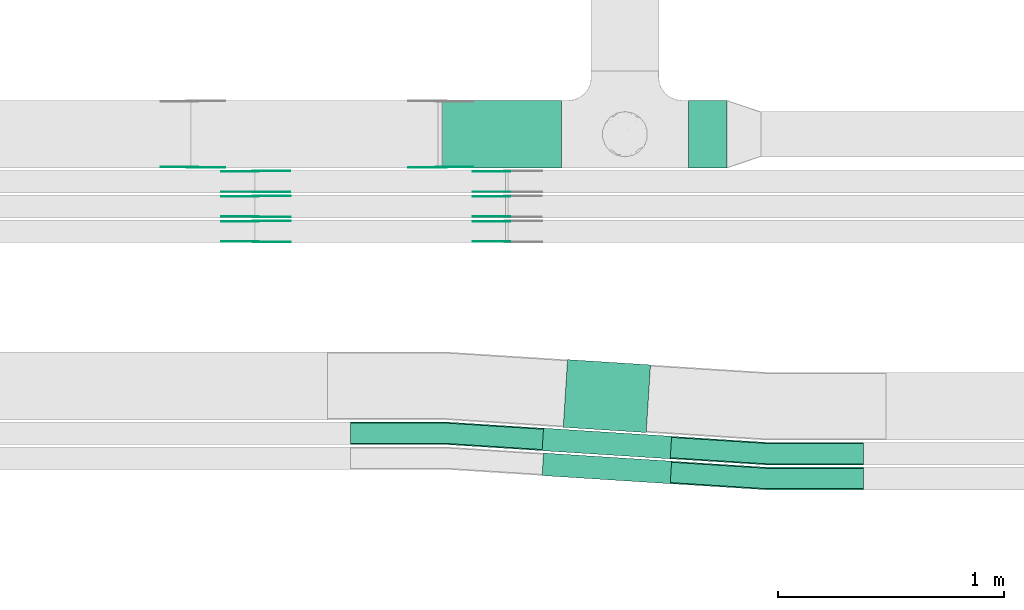
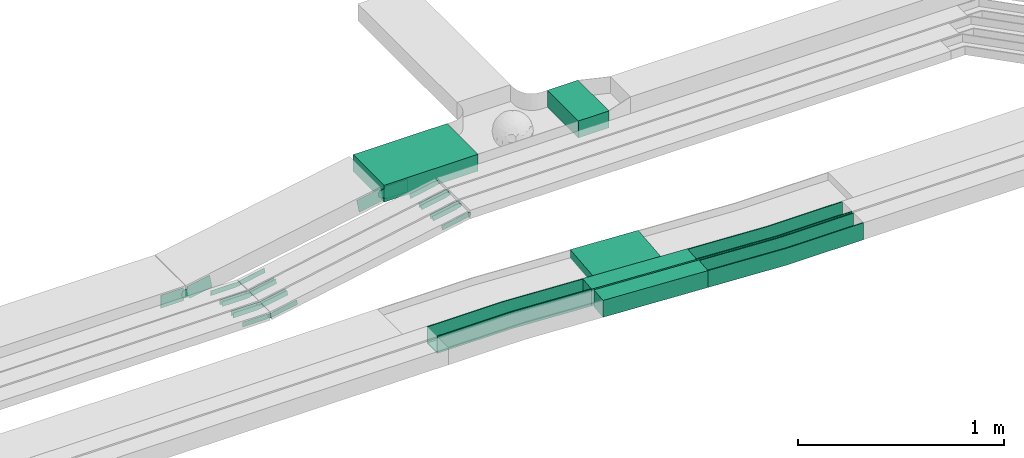
# One storey, part 11 of 32: 25 flow fittings, 5 flow segments.
"""IFC2X3 building model written with IfcOpenShell, lengths in millimetres."""

import ifcopenshell
import ifcopenshell.guid

model = None  # the IFC model being written
_history = None  # IfcOwnerHistory: only IFC2X3 demands one
_inside = {}  # id of a spatial element -> (the spatial element, [elements in it])
_under = {}  # id of a project, library or spatial element -> (it, [spatial elements below it])
_declared = {}  # id of a project -> (the project, [libraries it declares])
_typed = {}  # id of a type object -> (the type object, [elements of that type])
_made_of = {}  # id of a material, layer set ... -> (it, [elements and type objects made of it])


def new_model(schema):
    """Start an empty IFC model of exactly this schema.

    Asked for "IFC4X3", IfcOpenShell would pick the latest addendum, in which some entities
    have other attributes; the version numbers below select the first issue.
    IFC2X3 requires an IfcOwnerHistory on every rooted entity: one is made here for all.
    """
    global model, _history
    if schema == "IFC4X3":
        model = ifcopenshell.file(schema_version=(4, 3, 0, 0))
    else:
        model = ifcopenshell.file(schema=schema)
    _inside.clear()
    _under.clear()
    _declared.clear()
    _typed.clear()
    _made_of.clear()
    _history = None
    if model.schema == "IFC2X3":
        org = make("IfcOrganization", Name="unknown")
        user = make(
            "IfcPersonAndOrganization",
            ThePerson=make("IfcPerson", FamilyName="unknown"),
            TheOrganization=org,
        )
        app = make(
            "IfcApplication",
            ApplicationDeveloper=org,
            Version="unknown",
            ApplicationFullName="unknown",
            ApplicationIdentifier="unknown",
        )
        _history = make(
            "IfcOwnerHistory",
            OwningUser=user,
            OwningApplication=app,
            ChangeAction="ADDED",
            CreationDate=0,
        )
    return model


def make(cls, **values):
    """One entity of the class cls with the attributes given. An attribute that is None is left unset."""
    return model.create_entity(
        cls, **{name: value for name, value in values.items() if value is not None}
    )


def entity(cls, *values):
    """Any entity or typed value of the class cls, its attributes in the order of the schema. None: left unset."""
    e = model.create_entity(cls)
    for i, value in enumerate(values):
        if value is not None:
            e[i] = value
    return e


def rooted(cls, **values):
    """An entity with a GlobalId (a new one), such as an element, a storey or a relation."""
    return make(cls, GlobalId=ifcopenshell.guid.new(), OwnerHistory=_history, **values)


def si_unit(unit_type, name, prefix=None):
    """IfcSIUnit, for example si_unit("LENGTHUNIT", "METRE", prefix="MILLI")."""
    return make("IfcSIUnit", UnitType=unit_type, Prefix=prefix, Name=name)


def converted_unit(unit_type, name, factor, base, dimensions=None, offset=None):
    """IfcConversionBasedUnit, such as the inch: factor (a typed value) times the base unit."""
    return make(
        "IfcConversionBasedUnit"
        if offset is None
        else "IfcConversionBasedUnitWithOffset",
        ConversionOffset=offset,
        Dimensions=None
        if dimensions is None
        else entity("IfcDimensionalExponents", *dimensions),
        UnitType=unit_type,
        Name=name,
        ConversionFactor=make(
            "IfcMeasureWithUnit", ValueComponent=factor, UnitComponent=base
        ),
    )


def derived_unit(unit_type, elements):
    """IfcDerivedUnit: a product of units, each with its exponent."""
    return make(
        "IfcDerivedUnit",
        Elements=[
            make("IfcDerivedUnitElement", Unit=unit, Exponent=power)
            for unit, power in elements
        ],
        UnitType=unit_type,
    )


def assignment(units):
    """IfcUnitAssignment: the units of a project."""
    return None if units is None else make("IfcUnitAssignment", Units=units)


def point(xyz):
    """IfcCartesianPoint."""
    return None if xyz is None else make("IfcCartesianPoint", Coordinates=xyz)


def direction(xyz):
    """IfcDirection."""
    return None if xyz is None else make("IfcDirection", DirectionRatios=xyz)


def frame(location, z_axis=None, x_axis=None):
    """IfcAxis2Placement3D, a coordinate frame: its origin and axes. An axis left out is left unset."""
    return make(
        "IfcAxis2Placement3D",
        Location=point(location),
        Axis=direction(z_axis),
        RefDirection=direction(x_axis),
    )


def frame_2d(location, x_axis=None):
    """IfcAxis2Placement2D, a coordinate frame in the plane: its origin and x axis."""
    return make(
        "IfcAxis2Placement2D", Location=point(location), RefDirection=direction(x_axis)
    )


def origin():
    """The frame at (0, 0, 0) with its axes left unset."""
    return frame((0.0, 0.0, 0.0))


def origin_2d_with_axis():
    """The frame at (0, 0) in the plane with the x axis (1, 0) written out."""
    return frame_2d((0.0, 0.0), x_axis=(1.0, 0.0))


def place(relative_to, where):
    """IfcLocalPlacement: puts the frame where relative to a parent placement (None: the world)."""
    return make(
        "IfcLocalPlacement", PlacementRelTo=relative_to, RelativePlacement=where
    )


def context(
    kind, dimensions, precision=None, world=None, true_north=None, identifier=None
):
    """IfcGeometricRepresentationContext, for example the 3D "Model" context."""
    return make(
        "IfcGeometricRepresentationContext",
        ContextIdentifier=identifier,
        ContextType=kind,
        CoordinateSpaceDimension=dimensions,
        Precision=precision,
        WorldCoordinateSystem=world,
        TrueNorth=true_north,
    )


def subcontext(parent, identifier, kind, view, scale=None):
    """IfcGeometricRepresentationSubContext, for example "Body" below "Model"."""
    return make(
        "IfcGeometricRepresentationSubContext",
        ContextIdentifier=identifier,
        ContextType=kind,
        ParentContext=parent,
        TargetScale=scale,
        TargetView=view,
    )


def project(units=None, contexts=None):
    """IfcProject with its units and contexts."""
    return rooted(
        "IfcProject",
        Name="project",
        RepresentationContexts=contexts,
        UnitsInContext=assignment(units),
    )


def spatial(cls, under=None, at=None, **own):
    """A site, building, storey or space (cls), placed at a placement, below another one or the project."""
    s = rooted(cls, ObjectPlacement=at, **own)
    if under is not None:
        _under.setdefault(under.id(), (under, []))[1].append(s)
    return s


def polyline(points):
    """IfcPolyline through the points."""
    return make("IfcPolyline", Points=[point(p) for p in points])


def circle_curve(where, radius):
    """IfcCircle in the frame where."""
    return make("IfcCircle", Position=where, Radius=radius)


def parameter(value):
    """IfcParameterValue: where a trimmed curve begins or ends, as a parameter of its basis curve."""
    return model.create_entity("IfcParameterValue", value)


def trimmed(basis, trim1, trim2, sense, master):
    """IfcTrimmedCurve: the piece of a basis curve between two trims."""
    return make(
        "IfcTrimmedCurve",
        BasisCurve=basis,
        Trim1=trim1,
        Trim2=trim2,
        SenseAgreement=sense,
        MasterRepresentation=master,
    )


def segment(curve, same_sense, transition):
    """IfcCompositeCurveSegment."""
    return make(
        "IfcCompositeCurveSegment",
        Transition=transition,
        SameSense=same_sense,
        ParentCurve=curve,
    )


def composite_curve(segments, self_intersect=None):
    """IfcCompositeCurve: segments joined end to end."""
    return make("IfcCompositeCurve", Segments=segments, SelfIntersect=self_intersect)


def profile(cls, at=None, kind="AREA", **sizes):
    """A parametric profile (cls). Its sizes go by their IFC names, for example OverallWidth=200.0."""
    return make(cls, ProfileType=kind, Position=at, **sizes)


def rectangle(**sizes):
    """IfcRectangleProfileDef."""
    return profile("IfcRectangleProfileDef", **sizes)


def outline(outer, holes=None, kind="AREA"):
    """IfcArbitraryClosedProfileDef: a profile drawn as a closed curve; with holes, ...WithVoids."""
    if holes is None:
        return make("IfcArbitraryClosedProfileDef", ProfileType=kind, OuterCurve=outer)
    return make(
        "IfcArbitraryProfileDefWithVoids",
        ProfileType=kind,
        OuterCurve=outer,
        InnerCurves=holes,
    )


def extrude(swept, where, along, depth):
    """IfcExtrudedAreaSolid: the profile swept, set in the frame where, extruded along a direction by depth."""
    return make(
        "IfcExtrudedAreaSolid",
        SweptArea=swept,
        Position=where,
        ExtrudedDirection=direction(along),
        Depth=depth,
    )


def faces_of(points, faces, orient=None, outer=None):
    """IfcFace entities. A face is a list of loops; a loop is a list of indices into points, from 0.

    orient and outer hold one flag for each loop. By default every Orientation is true, the
    first loop of a face is its IfcFaceOuterBound and the others are IfcFaceBound.
    """
    made = []
    for i, loops in enumerate(faces):
        bounds = []
        for j, loop in enumerate(loops):
            is_outer = j == 0 if outer is None else outer[i][j]
            bounds.append(
                make(
                    "IfcFaceOuterBound" if is_outer else "IfcFaceBound",
                    Bound=make("IfcPolyLoop", Polygon=[points[k] for k in loop]),
                    Orientation=True if orient is None else orient[i][j],
                )
            )
        made.append(make("IfcFace", Bounds=bounds))
    return made


def faceted_brep(points, faces, orient=None, outer=None, voids=None):
    """IfcFacetedBrep: a solid bounded by flat faces; with voids (closed shells), ...WithVoids."""
    shared = [point(p) for p in points]
    hull = make("IfcClosedShell", CfsFaces=faces_of(shared, faces, orient, outer))
    if voids is None:
        return make("IfcFacetedBrep", Outer=hull)
    return make(
        "IfcFacetedBrepWithVoids",
        Outer=hull,
        Voids=[
            make(cls, CfsFaces=faces_of(shared, fs, o, b)) for cls, fs, o, b in voids
        ],
    )


def shape(context_of_items, identifier, shape_type, items):
    """IfcShapeRepresentation: the items that make up one representation, for example the "Body"."""
    return make(
        "IfcShapeRepresentation",
        ContextOfItems=context_of_items,
        RepresentationIdentifier=identifier,
        RepresentationType=shape_type,
        Items=items,
    )


def source(mapping_origin, context_of_items, identifier, shape_type, items):
    """IfcRepresentationMap: a shape defined once, which mapped items show again and again."""
    return make(
        "IfcRepresentationMap",
        MappingOrigin=mapping_origin,
        MappedRepresentation=shape(context_of_items, identifier, shape_type, items),
    )


def transform(
    local_origin,
    x_axis=None,
    y_axis=None,
    z_axis=None,
    scale=None,
    scale2=None,
    scale3=None,
    uniform=True,
):
    """IfcCartesianTransformationOperator3D, or its non-uniform kind. x_axis, y_axis, z_axis: its Axis1, 2, 3."""
    if uniform:
        return make(
            "IfcCartesianTransformationOperator3D",
            Axis1=direction(x_axis),
            Axis2=direction(y_axis),
            LocalOrigin=point(local_origin),
            Scale=scale,
            Axis3=direction(z_axis),
        )
    return make(
        "IfcCartesianTransformationOperator3DnonUniform",
        Axis1=direction(x_axis),
        Axis2=direction(y_axis),
        LocalOrigin=point(local_origin),
        Scale=scale,
        Axis3=direction(z_axis),
        Scale2=scale2,
        Scale3=scale3,
    )


def mapped(mapping_source, mapping_target):
    """IfcMappedItem: shows the shape of a source again, moved by a transform."""
    return make(
        "IfcMappedItem", MappingSource=mapping_source, MappingTarget=mapping_target
    )


def material(Name=None, Category=None):
    """IfcMaterial."""
    return make("IfcMaterial", Name=Name, Category=Category)


def made_of(thing, what):
    """Note that an element or type object is made of a material, layer set ...; save() writes the relation."""
    if what is not None:
        _made_of.setdefault(what.id(), (what, []))[1].append(thing)
    return thing


def type_object(cls, material=None, **own):
    """A type object (cls), such as IfcWallType, which elements share."""
    return made_of(rooted(cls, **own), material)


def type_shapes(of_type, sources):
    """Give a type object the sources (RepresentationMaps) that its elements show as mapped items."""
    of_type.RepresentationMaps = sources


def element(
    cls,
    number,
    at=None,
    inside=None,
    cuts=None,
    type_object=None,
    material=None,
    context=None,
    identifier="Body",
    shape_type=None,
    held_by="IfcProductDefinitionShape",
    body=None,
    shapes=None,
    **own,
):
    """One element of the class cls, such as IfcWall. Its Tag is "e" and its number.

    at: its placement. inside: the storey or other place that contains it. cuts: it is an
    opening in that element (IfcRelVoidsElement). A single representation is given by context,
    identifier, shape_type and body (its items); several are given by shapes. held_by: the class
    of the entity that holds the representations. save() writes the other relations.
    """
    e = rooted(cls, Tag="e%d" % number, ObjectPlacement=at, **own)
    if body is not None:
        shapes = [shape(context, identifier, shape_type, body)]
    if shapes is not None:
        e.Representation = make(held_by, Representations=shapes)
    if inside is not None:
        _inside.setdefault(inside.id(), (inside, []))[1].append(e)
    if cuts is not None:
        rooted(
            "IfcRelVoidsElement", RelatingBuildingElement=cuts, RelatedOpeningElement=e
        )
    if type_object is not None:
        _typed.setdefault(type_object.id(), (type_object, []))[1].append(e)
    return made_of(e, material)


def aggregate(whole, parts):
    """IfcRelAggregates: a whole, such as a stair, and the parts it consists of."""
    return rooted("IfcRelAggregates", RelatingObject=whole, RelatedObjects=parts)


def save(model, path):
    """Write the relations noted so far, then the file.

    IfcRelAggregates (storeys below a building ...), IfcRelContainedInSpatialStructure (elements
    in a storey), IfcRelDefinesByType, IfcRelAssociatesMaterial and IfcRelDeclares: one each for
    every whole, place, type object, material and project.
    """
    for whole, parts in _under.values():
        aggregate(whole, parts)
    for where, things in _inside.values():
        rooted(
            "IfcRelContainedInSpatialStructure",
            RelatedElements=things,
            RelatingStructure=where,
        )
    for kind, things in _typed.values():
        rooted("IfcRelDefinesByType", RelatedObjects=things, RelatingType=kind)
    for what, things in _made_of.values():
        rooted("IfcRelAssociatesMaterial", RelatedObjects=things, RelatingMaterial=what)
    for by, libraries in _declared.values():
        rooted("IfcRelDeclares", RelatingContext=by, RelatedDefinitions=libraries)
    model.write(path)


model = new_model("IFC2X3")

# Units and contexts
model_context = context("Model", 3, precision=0.01, world=origin(), true_north=direction((6.12303176911189e-17, 1.0)))
body_context = subcontext(model_context, "Body", "Model", "MODEL_VIEW")
ifc_project = project(units=[si_unit("LENGTHUNIT", "METRE", prefix="MILLI"), si_unit("AREAUNIT", "SQUARE_METRE"), si_unit("VOLUMEUNIT", "CUBIC_METRE"), converted_unit("PLANEANGLEUNIT", "DEGREE", entity("IfcRatioMeasure", 0.0174532925199433), si_unit("PLANEANGLEUNIT", "RADIAN"), dimensions=[0, 0, 0, 0, 0, 0, 0]), si_unit("MASSUNIT", "GRAM", prefix="KILO"), derived_unit("MASSDENSITYUNIT", [(si_unit("MASSUNIT", "GRAM", prefix="KILO"), 1), (si_unit("LENGTHUNIT", "METRE"), -3)]), derived_unit("MOMENTOFINERTIAUNIT", [(si_unit("LENGTHUNIT", "METRE"), 4)]), si_unit("TIMEUNIT", "SECOND"), si_unit("FREQUENCYUNIT", "HERTZ"), si_unit("THERMODYNAMICTEMPERATUREUNIT", "DEGREE_CELSIUS"), derived_unit("THERMALTRANSMITTANCEUNIT", [(si_unit("MASSUNIT", "GRAM", prefix="KILO"), 1), (si_unit("THERMODYNAMICTEMPERATUREUNIT", "KELVIN"), -1), (si_unit("TIMEUNIT", "SECOND"), -3)]), derived_unit("VOLUMETRICFLOWRATEUNIT", [(si_unit("LENGTHUNIT", "METRE"), 3), (si_unit("TIMEUNIT", "SECOND"), -1)]), derived_unit("MASSFLOWRATEUNIT", [(si_unit("MASSUNIT", "GRAM", prefix="KILO"), 1), (si_unit("TIMEUNIT", "SECOND"), -1)]), derived_unit("ROTATIONALFREQUENCYUNIT", [(si_unit("TIMEUNIT", "SECOND"), -1)]), si_unit("ELECTRICCURRENTUNIT", "AMPERE"), si_unit("ELECTRICVOLTAGEUNIT", "VOLT"), si_unit("POWERUNIT", "WATT"), si_unit("FORCEUNIT", "NEWTON", prefix="KILO"), si_unit("ILLUMINANCEUNIT", "LUX"), si_unit("LUMINOUSFLUXUNIT", "LUMEN"), si_unit("LUMINOUSINTENSITYUNIT", "CANDELA"), derived_unit("USERDEFINED", [(si_unit("MASSUNIT", "GRAM", prefix="KILO"), -1), (si_unit("LENGTHUNIT", "METRE"), -2), (si_unit("TIMEUNIT", "SECOND"), 3), (si_unit("LUMINOUSFLUXUNIT", "LUMEN"), 1)]), derived_unit("LINEARVELOCITYUNIT", [(si_unit("LENGTHUNIT", "METRE"), 1), (si_unit("TIMEUNIT", "SECOND"), -1)]), si_unit("PRESSUREUNIT", "PASCAL"), derived_unit("USERDEFINED", [(si_unit("LENGTHUNIT", "METRE"), -2), (si_unit("MASSUNIT", "GRAM", prefix="KILO"), 1), (si_unit("TIMEUNIT", "SECOND"), -2)]), derived_unit("LINEARFORCEUNIT", [(si_unit("MASSUNIT", "GRAM", prefix="KILO"), 1), (si_unit("LENGTHUNIT", "METRE"), 1), (si_unit("TIMEUNIT", "SECOND"), -2), (si_unit("LENGTHUNIT", "METRE"), -1)]), derived_unit("PLANARFORCEUNIT", [(si_unit("MASSUNIT", "GRAM", prefix="KILO"), 1), (si_unit("LENGTHUNIT", "METRE"), 1), (si_unit("TIMEUNIT", "SECOND"), -2), (si_unit("LENGTHUNIT", "METRE"), -2)])], contexts=[model_context])

# Site, building, storey
site_placement = place(None, origin())
site = spatial("IfcSite", under=ifc_project, at=site_placement, CompositionType="ELEMENT")
building_placement = place(site_placement, origin())
building = spatial("IfcBuilding", under=site, at=building_placement, CompositionType="ELEMENT")
storey_placement = place(building_placement, frame((0.0, 0.0, 8100.0)))
storey = spatial("IfcBuildingStorey", under=building, at=storey_placement, CompositionType="ELEMENT", Elevation=8100.0)

# Flow segments
cable_carrier_segment_type = type_object("IfcCableCarrierSegmentType", PredefinedType="CABLETRAYSEGMENT")
flow_segment_1_placement = place(storey_placement, frame((27371.01, 9845.0, 2800.0)))
element("IfcFlowSegment", 1, at=flow_segment_1_placement, inside=storey, type_object=cable_carrier_segment_type, context=body_context, shape_type="SweptSolid", body=[
    extrude(rectangle(XDim=172.000000000026, YDim=300.000000000001, at=origin_2d_with_axis()), frame((86.0, 150.0, 0.0), z_axis=(0.0, 0.0, 1.0), x_axis=(-1.0, 0.0, 0.0)), (0.0, 0.0, 1.0), 99.9999999999989),
])
flow_segment_2_placement = place(storey_placement, frame((26284.49, 9845.0, 2800.0)))
element("IfcFlowSegment", 2, at=flow_segment_2_placement, inside=storey, type_object=cable_carrier_segment_type, context=body_context, shape_type="SweptSolid", body=[
    extrude(rectangle(XDim=526.511451475801, YDim=300.000000000001, at=origin_2d_with_axis()), frame((263.26, 150.0, 0.0), z_axis=(0.0, 0.0, 1.0), x_axis=(-1.0, 0.0, 0.0)), (0.0, 0.0, 1.0), 99.9999999999989),
])
flow_segment_3_placement = place(storey_placement, frame((26724.59, 8449.56, 2789.32)))
element("IfcFlowSegment", 3, at=flow_segment_3_placement, inside=storey, type_object=cable_carrier_segment_type, context=body_context, shape_type="SweptSolid", body=[
    extrude(rectangle(XDim=567.694436717267, YDim=100.000000000001, at=origin_2d_with_axis()), frame((286.45, 67.89, 0.0), z_axis=(0.0, 0.0, 1.0), x_axis=(-0.997988582354139, 0.0633939231375962, 0.0)), (0.0, 0.0, 1.0), 99.9999999999989),
])
flow_segment_4_placement = place(storey_placement, frame((26818.05, 8675.69, 2790.02)))
element("IfcFlowSegment", 4, at=flow_segment_4_placement, inside=storey, type_object=cable_carrier_segment_type, context=body_context, shape_type="SweptSolid", body=[
    extrude(rectangle(XDim=367.694436689472, YDim=300.000000000001, at=origin_2d_with_axis()), frame((192.99, 161.35, 0.0), z_axis=(0.0, 0.0, 1.0), x_axis=(0.997988582354136, -0.0633939231376403, 0.0)), (0.0, 0.0, 1.0), 50.0000000000016),
])
flow_segment_5_placement = place(storey_placement, frame((26724.59, 8559.56, 2789.67)))
element("IfcFlowSegment", 5, at=flow_segment_5_placement, inside=storey, type_object=cable_carrier_segment_type, context=body_context, shape_type="SweptSolid", body=[
    extrude(rectangle(XDim=567.694436717637, YDim=100.000000000001, at=origin_2d_with_axis()), frame((286.45, 67.89, 0.0), z_axis=(0.0, 0.0, 1.0), x_axis=(-0.997988582354137, 0.0633939231376368, 0.0)), (0.0, 0.0, 1.0), 99.9999999999989),
])

# Flow fittings
ifc_material_1 = material()
cable_carrier_fitting_type_1 = type_object("IfcCableCarrierFittingType", Name="470_DKC_G5_Sheet horizontal bend:-", PredefinedType="NOTDEFINED", material=ifc_material_1)
shared_shape_1 = source(origin(), body_context, "Body", "Brep", [
    faceted_brep([(-426.0, -50.0, -50.0), (-426.0, -50.0, 50.0), (-426.0, -45.0, 50.0), (-426.0, -45.0, -45.0), (-426.0, 45.0, -45.0), (-426.0, 45.0, 50.0), (-426.0, 50.0, 50.0), (-426.0, 50.0, -50.0), (1.59, -50.0, -50.0), (1.59, -50.0, 50.0), (428.31, -22.89, 50.0), (428.0, -17.9, 50.0), (1.43, -45.0, 50.0), (1.43, -45.0, -45.0), (428.0, -17.9, -45.0), (422.29, 71.92, -45.0), (-1.43, 45.0, -45.0), (-1.43, 45.0, 50.0), (422.29, 71.92, 50.0), (421.97, 76.91, 50.0), (-1.59, 50.0, 50.0), (-1.59, 50.0, -50.0), (421.97, 76.91, -50.0), (428.31, -22.89, -50.0)], [[[0, 1, 2, 3, 4, 5, 6, 7]], [[1, 0, 8, 9]], [[2, 1, 9, 10, 11, 12]], [[3, 2, 12, 13]], [[4, 3, 13, 14, 15, 16]], [[5, 4, 16, 17]], [[6, 5, 17, 18, 19, 20]], [[7, 6, 20, 21]], [[8, 0, 7, 21, 22, 23]], [[23, 22, 19, 18, 15, 14, 11, 10]], [[9, 8, 23, 10]], [[13, 12, 11, 14]], [[17, 16, 15, 18]], [[21, 20, 19, 22]]]),
])
type_shapes(cable_carrier_fitting_type_1, [shared_shape_1])
for number, where, z_axis, x_axis, name in (
    (6, (27719.46, 8582.45, 2839.67), (0.0, 0.0, 1.0), (0.997988582354139, -0.0633939231376085, 0.0), "470_DKC_G5_Sheet horizontal bend:-"),
    (7, (27719.46, 8472.45, 2839.32), (0.0, 0.0, 1.0), (0.997988582354141, -0.0633939231375666, 0.0), "470_DKC_G5_Sheet horizontal bend:-"),
    (8, (26302.62, 8672.45, 2839.67), (0.0, 0.0, 1.0), (-0.997988582354137, 0.0633939231376368, 0.0), "470_DKC_G5_Sheet horizontal bend:-"),
):
    element("IfcFlowFitting", number, at=place(storey_placement, frame(where, z_axis=z_axis, x_axis=x_axis)), inside=storey, type_object=cable_carrier_fitting_type_1, material=ifc_material_1, Name=name, ObjectType="470_DKC_G5_Sheet horizontal bend:-", context=body_context, shape_type="MappedRepresentation", body=[
        mapped(shared_shape_1, transform((0.0, 0.0, 0.0), scale=1.0)),
    ])
ifc_material_2 = material(Name="G")
cable_carrier_fitting_type_2 = type_object("IfcCableCarrierFittingType", PredefinedType="NOTDEFINED", material=ifc_material_2)
shared_shape_2 = source(origin(), body_context, "Body", "SweptSolid", [
    extrude(outline(composite_curve([segment(trimmed(circle_curve(frame_2d((-44.59, 0.0), x_axis=(1.0, 0.0)), 12.5), [parameter(90.0000000000007)], [parameter(270.0)], True, "PARAMETER"), True, "CONTINUOUS"), segment(polyline([(-44.59, -12.5), (-33.09, -12.5)]), True, "CONTINUOUS"), segment(polyline([(-33.09, -12.5), (-31.23, -14.5)]), True, "CONTINUOUS"), segment(polyline([(-31.23, -14.5), (108.91, -14.5)]), True, "CONTINUOUS"), segment(polyline([(108.91, -14.5), (108.91, 14.5)]), True, "CONTINUOUS"), segment(polyline([(108.91, 14.5), (-31.23, 14.5)]), True, "CONTINUOUS"), segment(polyline([(-31.23, 14.5), (-33.09, 12.5)]), True, "CONTINUOUS"), segment(polyline([(-33.09, 12.5), (-44.59, 12.5)]), True, "CONTINUOUS")], self_intersect=False)), frame((44.59, 0.0, 0.0), z_axis=(0.0, 0.0, -1.0), x_axis=(1.0, 0.0, 0.0)), (0.0, 0.0, -1.0), 2.0),
])
type_shapes(cable_carrier_fitting_type_2, [shared_shape_2])
flow_fitting_1_placement = place(storey_placement, frame((25458.53, 9520.02, 2615.49), z_axis=(0.0, -1.0, 0.0), x_axis=(0.982730588994864, 0.0, 0.185042128862072)))
element("IfcFlowFitting", 9, at=flow_fitting_1_placement, inside=storey, type_object=cable_carrier_fitting_type_2, material=ifc_material_2, context=body_context, shape_type="MappedRepresentation", body=[
    mapped(shared_shape_2, transform((0.0, 0.0, 0.0), scale=1.0)),
])
cable_carrier_fitting_type_3 = type_object("IfcCableCarrierFittingType", PredefinedType="NOTDEFINED", material=ifc_material_2)
type_shapes(cable_carrier_fitting_type_3, [shared_shape_2])
flow_fitting_2_placement = place(storey_placement, frame((25458.53, 9608.94, 2615.49), z_axis=(0.0, 1.0, 0.0), x_axis=(-1.0, 0.0, 0.0)))
element("IfcFlowFitting", 10, at=flow_fitting_2_placement, inside=storey, type_object=cable_carrier_fitting_type_3, material=ifc_material_2, context=body_context, shape_type="MappedRepresentation", body=[
    mapped(shared_shape_2, transform((0.0, 0.0, 0.0), scale=1.0)),
])
flow_fitting_3_placement = place(storey_placement, frame((25458.53, 9630.02, 2615.43), z_axis=(0.0, -1.0, 0.0), x_axis=(0.982701539841557, 0.0, 0.185196337957945)))
element("IfcFlowFitting", 11, at=flow_fitting_3_placement, inside=storey, type_object=cable_carrier_fitting_type_2, material=ifc_material_2, context=body_context, shape_type="MappedRepresentation", body=[
    mapped(shared_shape_2, transform((0.0, 0.0, 0.0), scale=1.0)),
])
flow_fitting_4_placement = place(storey_placement, frame((25458.53, 9718.94, 2615.43), z_axis=(0.0, 1.0, 0.0), x_axis=(-1.0, 0.0, 0.0)))
element("IfcFlowFitting", 12, at=flow_fitting_4_placement, inside=storey, type_object=cable_carrier_fitting_type_3, material=ifc_material_2, context=body_context, shape_type="MappedRepresentation", body=[
    mapped(shared_shape_2, transform((0.0, 0.0, 0.0), scale=1.0)),
])
flow_fitting_5_placement = place(storey_placement, frame((25458.53, 9739.54, 2614.16), z_axis=(0.0, -1.0, 0.0), x_axis=(0.982500640063244, 0.0, 0.186259207222932)))
element("IfcFlowFitting", 13, at=flow_fitting_5_placement, inside=storey, type_object=cable_carrier_fitting_type_2, material=ifc_material_2, context=body_context, shape_type="MappedRepresentation", body=[
    mapped(shared_shape_2, transform((0.0, 0.0, 0.0), scale=1.0)),
])
for number, where, z_axis, x_axis in (
    (14, (25458.53, 9828.46, 2614.16), (0.0, 1.0, 0.0), (-1.0, 0.0, 0.0)),
    (15, (26571.19, 9522.02, 2825.0), (0.0, -1.0, 0.0), (-0.982730588994865, 0.0, -0.185042128862065)),
    (16, (26570.55, 9632.02, 2825.0), (0.0, -1.0, 0.0), (-0.982701539841558, 0.0, -0.185196337957939)),
    (17, (26570.71, 9741.54, 2825.0), (0.0, -1.0, 0.0), (-0.982500640063246, 0.0, -0.186259207222926)),
):
    element("IfcFlowFitting", number, at=place(storey_placement, frame(where, z_axis=z_axis, x_axis=x_axis)), inside=storey, type_object=cable_carrier_fitting_type_3, material=ifc_material_2, context=body_context, shape_type="MappedRepresentation", body=[
        mapped(shared_shape_2, transform((0.0, 0.0, 0.0), scale=1.0)),
    ])
cable_carrier_fitting_type_4 = type_object("IfcCableCarrierFittingType", PredefinedType="NOTDEFINED", material=ifc_material_2)
shared_shape_3 = source(origin(), body_context, "Body", "SweptSolid", [
    extrude(outline(composite_curve([segment(trimmed(circle_curve(frame_2d((-44.59, 0.0), x_axis=(1.0, 0.0)), 12.5), [parameter(90.0000000000007)], [parameter(270.0)], True, "PARAMETER"), True, "CONTINUOUS"), segment(polyline([(-44.59, -12.5), (-33.09, -12.5)]), True, "CONTINUOUS"), segment(polyline([(-33.09, -12.5), (-31.23, -14.5)]), True, "CONTINUOUS"), segment(polyline([(-31.23, -14.5), (108.91, -14.5)]), True, "CONTINUOUS"), segment(polyline([(108.91, -14.5), (108.91, 14.5)]), True, "CONTINUOUS"), segment(polyline([(108.91, 14.5), (-31.23, 14.5)]), True, "CONTINUOUS"), segment(polyline([(-31.23, 14.5), (-33.09, 12.5)]), True, "CONTINUOUS"), segment(polyline([(-33.09, 12.5), (-44.59, 12.5)]), True, "CONTINUOUS")], self_intersect=False)), frame((44.59, 0.0, 0.0)), (0.0, 0.0, 1.0), 2.0),
])
type_shapes(cable_carrier_fitting_type_4, [shared_shape_3])
flow_fitting_6_placement = place(storey_placement, frame((25458.53, 9610.94, 2615.49), z_axis=(0.0, 1.0, 0.0), x_axis=(0.982730588994864, 0.0, 0.185042128862072)))
element("IfcFlowFitting", 18, at=flow_fitting_6_placement, inside=storey, type_object=cable_carrier_fitting_type_4, material=ifc_material_2, context=body_context, shape_type="MappedRepresentation", body=[
    mapped(shared_shape_3, transform((0.0, 0.0, 0.0), scale=1.0)),
])
cable_carrier_fitting_type_5 = type_object("IfcCableCarrierFittingType", PredefinedType="NOTDEFINED", material=ifc_material_2)
type_shapes(cable_carrier_fitting_type_5, [shared_shape_3])
flow_fitting_7_placement = place(storey_placement, frame((25458.53, 9522.02, 2615.49), z_axis=(0.0, -1.0, 0.0), x_axis=(-1.0, 0.0, 0.0)))
element("IfcFlowFitting", 19, at=flow_fitting_7_placement, inside=storey, type_object=cable_carrier_fitting_type_5, material=ifc_material_2, context=body_context, shape_type="MappedRepresentation", body=[
    mapped(shared_shape_3, transform((0.0, 0.0, 0.0), scale=1.0)),
])
flow_fitting_8_placement = place(storey_placement, frame((25458.53, 9720.94, 2615.43), z_axis=(0.0, 1.0, 0.0), x_axis=(0.982701539841557, 0.0, 0.185196337957945)))
element("IfcFlowFitting", 20, at=flow_fitting_8_placement, inside=storey, type_object=cable_carrier_fitting_type_4, material=ifc_material_2, context=body_context, shape_type="MappedRepresentation", body=[
    mapped(shared_shape_3, transform((0.0, 0.0, 0.0), scale=1.0)),
])
flow_fitting_9_placement = place(storey_placement, frame((25458.53, 9632.02, 2615.43), z_axis=(0.0, -1.0, 0.0), x_axis=(-1.0, 0.0, 0.0)))
element("IfcFlowFitting", 21, at=flow_fitting_9_placement, inside=storey, type_object=cable_carrier_fitting_type_5, material=ifc_material_2, context=body_context, shape_type="MappedRepresentation", body=[
    mapped(shared_shape_3, transform((0.0, 0.0, 0.0), scale=1.0)),
])
flow_fitting_10_placement = place(storey_placement, frame((25458.53, 9830.46, 2614.16), z_axis=(0.0, 1.0, 0.0), x_axis=(0.982500640063244, 0.0, 0.186259207222932)))
element("IfcFlowFitting", 22, at=flow_fitting_10_placement, inside=storey, type_object=cable_carrier_fitting_type_4, material=ifc_material_2, context=body_context, shape_type="MappedRepresentation", body=[
    mapped(shared_shape_3, transform((0.0, 0.0, 0.0), scale=1.0)),
])
for number, where, z_axis, x_axis in (
    (23, (25458.53, 9741.54, 2614.16), (0.0, -1.0, 0.0), (-1.0, 0.0, 0.0)),
    (24, (26571.19, 9608.94, 2825.0), (0.0, 1.0, 0.0), (-0.982730588994865, 0.0, -0.185042128862065)),
    (25, (26570.55, 9718.94, 2825.0), (0.0, 1.0, 0.0), (-0.982701539841558, 0.0, -0.185196337957939)),
    (26, (26570.71, 9828.46, 2825.0), (0.0, 1.0, 0.0), (-0.982500640063246, 0.0, -0.186259207222926)),
):
    element("IfcFlowFitting", number, at=place(storey_placement, frame(where, z_axis=z_axis, x_axis=x_axis)), inside=storey, type_object=cable_carrier_fitting_type_5, material=ifc_material_2, context=body_context, shape_type="MappedRepresentation", body=[
        mapped(shared_shape_3, transform((0.0, 0.0, 0.0), scale=1.0)),
    ])
cable_carrier_fitting_type_6 = type_object("IfcCableCarrierFittingType", PredefinedType="NOTDEFINED", material=ifc_material_2)
shared_shape_4 = source(origin(), body_context, "Body", "SweptSolid", [
    extrude(outline(composite_curve([segment(trimmed(circle_curve(frame_2d((-41.47, 0.0), x_axis=(1.0, 0.0)), 25.0), [parameter(90.0000000000007)], [parameter(270.0)], True, "PARAMETER"), True, "CONTINUOUS"), segment(polyline([(-41.47, -25.0), (-29.97, -25.0)]), True, "CONTINUOUS"), segment(polyline([(-29.97, -25.0), (-28.1, -38.5)]), True, "CONTINUOUS"), segment(polyline([(-28.1, -38.5), (99.53, -38.5)]), True, "CONTINUOUS"), segment(polyline([(99.53, -38.5), (99.53, 38.5)]), True, "CONTINUOUS"), segment(polyline([(99.53, 38.5), (-28.1, 38.5)]), True, "CONTINUOUS"), segment(polyline([(-28.1, 38.5), (-29.97, 25.0)]), True, "CONTINUOUS"), segment(polyline([(-29.97, 25.0), (-41.47, 25.0)]), True, "CONTINUOUS")], self_intersect=False)), frame((41.47, 0.0, 0.0), z_axis=(0.0, 0.0, -1.0), x_axis=(1.0, 0.0, 0.0)), (0.0, 0.0, -1.0), 2.0),
])
type_shapes(cable_carrier_fitting_type_6, [shared_shape_4])
for number, where, z_axis, x_axis in (
    (27, (25178.53, 9849.54, 2645.02), (0.0, -1.0, 0.0), (0.983076107251628, 0.0, 0.183197618300528)),
    (28, (26278.51, 9849.54, 2850.0), (0.0, -1.0, 0.0), (-0.983076107251628, 0.0, -0.183197618300528)),
):
    element("IfcFlowFitting", number, at=place(storey_placement, frame(where, z_axis=z_axis, x_axis=x_axis)), inside=storey, type_object=cable_carrier_fitting_type_6, material=ifc_material_2, context=body_context, shape_type="MappedRepresentation", body=[
        mapped(shared_shape_4, transform((0.0, 0.0, 0.0), scale=1.0)),
    ])
cable_carrier_fitting_type_7 = type_object("IfcCableCarrierFittingType", PredefinedType="NOTDEFINED", material=ifc_material_2)
shared_shape_5 = source(origin(), body_context, "Body", "SweptSolid", [
    extrude(outline(composite_curve([segment(trimmed(circle_curve(frame_2d((-41.47, 0.0), x_axis=(1.0, 0.0)), 25.0), [parameter(90.0000000000007)], [parameter(270.0)], True, "PARAMETER"), True, "CONTINUOUS"), segment(polyline([(-41.47, -25.0), (-29.97, -25.0)]), True, "CONTINUOUS"), segment(polyline([(-29.97, -25.0), (-28.1, -38.5)]), True, "CONTINUOUS"), segment(polyline([(-28.1, -38.5), (99.53, -38.5)]), True, "CONTINUOUS"), segment(polyline([(99.53, -38.5), (99.53, 38.5)]), True, "CONTINUOUS"), segment(polyline([(99.53, 38.5), (-28.1, 38.5)]), True, "CONTINUOUS"), segment(polyline([(-28.1, 38.5), (-29.97, 25.0)]), True, "CONTINUOUS"), segment(polyline([(-29.97, 25.0), (-41.47, 25.0)]), True, "CONTINUOUS")], self_intersect=False)), frame((41.47, 0.0, 0.0)), (0.0, 0.0, 1.0), 2.0),
])
type_shapes(cable_carrier_fitting_type_7, [shared_shape_5])
for number, where, z_axis, x_axis in (
    (29, (25178.53, 9851.54, 2645.02), (0.0, -1.0, 0.0), (-1.0, 0.0, 0.0)),
    (30, (26278.51, 9851.54, 2850.0), (0.0, -1.0, 0.0), (1.0, 0.0, 0.0)),
):
    element("IfcFlowFitting", number, at=place(storey_placement, frame(where, z_axis=z_axis, x_axis=x_axis)), inside=storey, type_object=cable_carrier_fitting_type_7, material=ifc_material_2, context=body_context, shape_type="MappedRepresentation", body=[
        mapped(shared_shape_5, transform((0.0, 0.0, 0.0), scale=1.0)),
    ])

save(model, "model.ifc")
